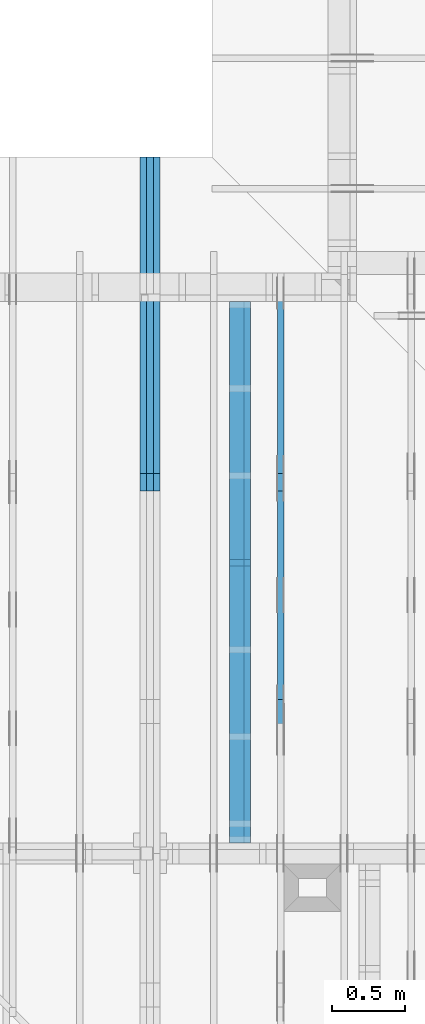
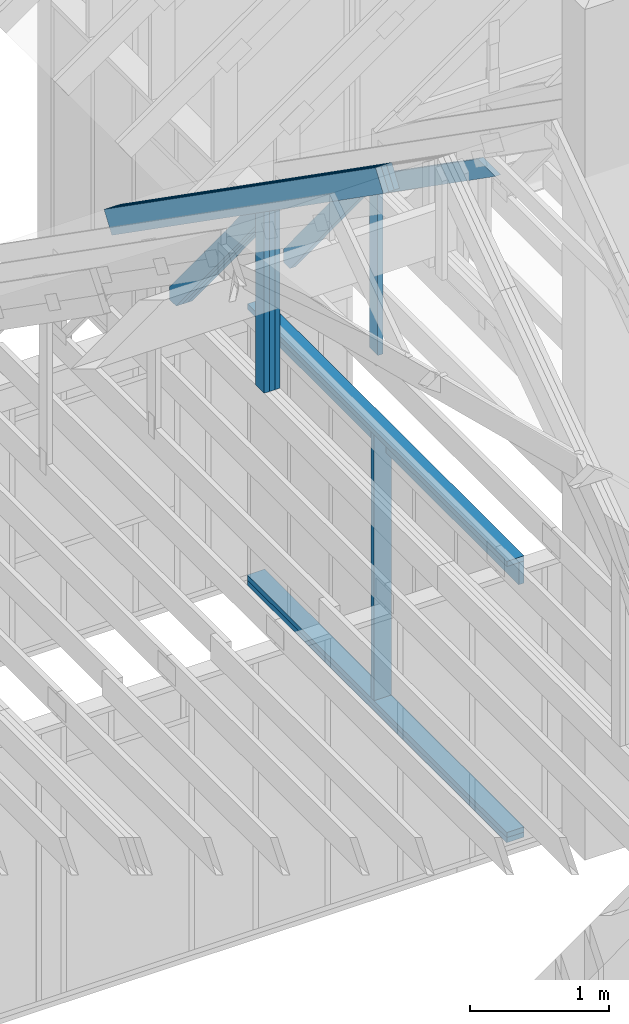
# One storey, part 18 of 70: 17 members, 3 elements without a shape of their own.
"""IFC2X3 building model written with IfcOpenShell, lengths in millimetres."""

from ifc_helpers import new_model, si_unit, frame, origin, origin_with_axes, origin_2d, place, context, project, spatial, faceted_brep, element, aggregate, save


model = new_model("IFC2X3")

# Units and contexts
model_context = context("Model", 3, precision=1e-05, world=origin())
plan_context = context("Plan", 2, precision=1e-05, world=origin_2d())
ifc_project = project(units=[si_unit("LENGTHUNIT", "METRE", prefix="MILLI"), si_unit("AREAUNIT", "SQUARE_METRE"), si_unit("VOLUMEUNIT", "CUBIC_METRE"), si_unit("SOLIDANGLEUNIT", "STERADIAN"), si_unit("PLANEANGLEUNIT", "RADIAN"), si_unit("MASSUNIT", "GRAM"), si_unit("TIMEUNIT", "SECOND"), si_unit("THERMODYNAMICTEMPERATUREUNIT", "DEGREE_CELSIUS"), si_unit("LUMINOUSINTENSITYUNIT", "LUMEN")], contexts=[model_context, plan_context])

# Site, building, storey
site_placement = place(None, origin_with_axes())
site = spatial("IfcSite", under=ifc_project, at=site_placement, CompositionType="ELEMENT")
building_placement = place(site_placement, origin_with_axes())
building = spatial("IfcBuilding", under=site, at=building_placement, Name="Layout 1", CompositionType="ELEMENT")
storey_placement = place(building_placement, origin_with_axes())
storey = spatial("IfcBuildingStorey", under=building, at=storey_placement, Name="Storey 1", CompositionType="ELEMENT", Elevation=0.0)

# Assembly, members
assembly_1_placement = place(storey_placement, frame((5660.000000000293, 8000.0, 9.122500660690286e-13), z_axis=(-1.0, 1.836909530733566e-16, 6.123031769111886e-17), x_axis=(-1.836909530733566e-16, -1.0, 0.0)))
assembly_1 = element("IfcElementAssembly", 1, at=assembly_1_placement, inside=storey, Name="T11", AssemblyPlace="FACTORY", PredefinedType="TRUSS")
member_1_placement = place(assembly_1_placement, frame((-688.1525949112561, 280.0993207951618, -90.0), z_axis=(0.0, 0.0, 1.0), x_axis=(0.8191520442889916, 0.5735764363510464, 0.0)))
member_1 = element("IfcMember", 2, at=member_1_placement, Name="T9", context=model_context, shape_type="Brep", body=[
    faceted_brep([(4768.153825500515, 195.00000000101568, 45.0), (0.0, 195.00000000101568, 45.0), (3.9250380723387934e-10, 0.0, 45.0), (4768.153825500451, 0.0, 45.0), (0.0, 195.00000000101568, 0.0), (4768.153825500515, 195.00000000101568, 5.839111470710405e-13), (4768.153825500451, 0.0, 5.839111470710327e-13), (3.9250380723387934e-10, 0.0, 4.806626562380822e-26), (3.925038072338794e-10, 9.4039548065783e-38, -2.8698592549372254e-42), (3.925065625981755e-10, 5.545142647084054e-27, 45.0), (7.104410816346931e-14, 195.00000000050545, 45.0), (6.828874386736896e-14, 195.00000000050545, -4.181341481726627e-30), (4768.153825500451, 3.103358117890669e-09, 7.360169588463904e-29), (4768.153825500451, 3.103360873254965e-09, 45.0), (3.9250380723387934e-10, 2.755364296001399e-15, 45.0), (3.9250380723387934e-10, -9.894980083356221e-26, 6.058727740512586e-42), (4768.153825500451, 195.00000000101568, -3.937993638863291e-27), (4768.153825500451, 195.00000000101568, 45.0), (4768.153825500451, 3.1045601645018905e-09, 45.0), (4768.153825500451, 3.1045601645018905e-09, 0.0), (0.0, 195.00000000050545, 0.0), (0.0, 195.00000000050545, 45.0), (4768.153825500515, 195.00000000101548, 45.0), (4768.153825500515, 195.00000000101548, -1.262177448353619e-29)], [[[0, 1, 2, 3]], [[4, 5, 6, 7]], [[8, 9, 10, 11]], [[12, 13, 14, 15]], [[16, 17, 18, 19]], [[20, 21, 22, 23]]]),
])
member_2_placement = place(assembly_1_placement, frame((-688.1525949112561, 280.0993207951618, -135.0), z_axis=(0.0, 0.0, 1.0), x_axis=(0.8191520442889916, 0.5735764363510464, 0.0)))
member_2 = element("IfcMember", 3, at=member_2_placement, Name="T9", context=model_context, shape_type="Brep", body=[
    faceted_brep([(4768.153825500515, 195.00000000101568, 45.0), (0.0, 195.00000000101568, 45.0), (3.9250380723387934e-10, 0.0, 45.0), (4768.153825500451, 0.0, 45.0), (0.0, 195.00000000101568, 0.0), (4768.153825500515, 195.00000000101568, 5.839111470710405e-13), (4768.153825500451, 0.0, 5.839111470710327e-13), (3.9250380723387934e-10, 0.0, 4.806626562380822e-26), (3.925038072338794e-10, 9.4039548065783e-38, -2.8698592549372254e-42), (3.925065625981755e-10, 5.545142647084054e-27, 45.0), (7.104410816346931e-14, 195.00000000050545, 45.0), (6.828874386736896e-14, 195.00000000050545, -4.181341481726627e-30), (4768.153825500451, 3.103358117890669e-09, 7.360169588463904e-29), (4768.153825500451, 3.103360873254965e-09, 45.0), (3.9250380723387934e-10, 2.755364296001399e-15, 45.0), (3.9250380723387934e-10, -9.894980083356221e-26, 6.058727740512586e-42), (4768.153825500451, 195.00000000101568, -3.937993638863291e-27), (4768.153825500451, 195.00000000101568, 45.0), (4768.153825500451, 3.1045601645018905e-09, 45.0), (4768.153825500451, 3.1045601645018905e-09, 0.0), (0.0, 195.00000000050545, 0.0), (0.0, 195.00000000050545, 45.0), (4768.153825500515, 195.00000000101548, 45.0), (4768.153825500515, 195.00000000101548, -1.262177448353619e-29)], [[[0, 1, 2, 3]], [[4, 5, 6, 7]], [[8, 9, 10, 11]], [[12, 13, 14, 15]], [[16, 17, 18, 19]], [[20, 21, 22, 23]]]),
])
member_3_placement = place(assembly_1_placement, frame((-688.1525949112561, 280.0993207951618, -180.0), z_axis=(0.0, 0.0, 1.0), x_axis=(0.8191520442889916, 0.5735764363510464, 0.0)))
member_3 = element("IfcMember", 4, at=member_3_placement, Name="T9", context=model_context, shape_type="Brep", body=[
    faceted_brep([(4768.153825500515, 195.00000000101568, 45.0), (0.0, 195.00000000101568, 45.0), (3.9250380723387934e-10, 0.0, 45.0), (4768.153825500451, 0.0, 45.0), (0.0, 195.00000000101568, 0.0), (4768.153825500515, 195.00000000101568, 5.839111470710405e-13), (4768.153825500451, 0.0, 5.839111470710327e-13), (3.9250380723387934e-10, 0.0, 4.806626562380822e-26), (3.925038072338794e-10, 9.4039548065783e-38, -2.8698592549372254e-42), (3.925065625981755e-10, 5.545142647084054e-27, 45.0), (7.104410816346931e-14, 195.00000000050545, 45.0), (6.828874386736896e-14, 195.00000000050545, -4.181341481726627e-30), (4768.153825500451, 3.103358117890669e-09, 7.360169588463904e-29), (4768.153825500451, 3.103360873254965e-09, 45.0), (3.9250380723387934e-10, 2.755364296001399e-15, 45.0), (3.9250380723387934e-10, -9.894980083356221e-26, 6.058727740512586e-42), (4768.153825500451, 195.00000000101568, -3.937993638863291e-27), (4768.153825500451, 195.00000000101568, 45.0), (4768.153825500451, 3.1045601645018905e-09, 45.0), (4768.153825500451, 3.1045601645018905e-09, 0.0), (0.0, 195.00000000050545, 0.0), (0.0, 195.00000000050545, 45.0), (4768.153825500515, 195.00000000101548, 45.0), (4768.153825500515, 195.00000000101548, -1.262177448353619e-29)], [[[0, 1, 2, 3]], [[4, 5, 6, 7]], [[8, 9, 10, 11]], [[12, 13, 14, 15]], [[16, 17, 18, 19]], [[20, 21, 22, 23]]]),
])
member_4_placement = place(assembly_1_placement, frame((1380.0000000018192, 1812.2602625085638, -90.0), z_axis=(0.0, 0.0, 1.0), x_axis=(-1.836909530733566e-16, -1.0, 0.0)))
member_4 = element("IfcMember", 5, at=member_4_placement, Name="R1", context=model_context, shape_type="Brep", body=[
    faceted_brep([(1592.2602625085638, 120.00000000001455, 45.0), (0.0, 120.00000000001455, 45.0), (84.02490458526881, 1.432454155292362e-11, 45.0), (1592.2602625085638, 1.432454155292362e-11, 45.0), (0.0, 120.00000000001455, 0.0), (1592.2602625085638, 120.00000000001455, 1.9498920344068735e-13), (1592.2602625085638, 1.432454155292362e-11, 1.9498920344068735e-13), (84.02490458526881, 1.432454155292362e-11, 1.0289743203443919e-14), (84.0249045852688, 1.4303225270850817e-11, 1.5777218104420236e-30), (84.02490458526881, 1.4303225270850817e-11, 45.0), (2.1316282072803006e-14, 120.00000000001435, 45.0), (2.1316282072803006e-14, 120.00000000001435, -2.3665827156630354e-30), (1592.2602625085638, -7.262347142616226e-13, 4.446758227255812e-29), (1592.2602625085638, -7.234793499655223e-13, 45.0), (84.02490458526881, 1.4288972904488156e-11, 45.0), (84.02490458526881, 1.4286217540192056e-11, 2.3465914747521543e-30), (1592.2602625085638, 120.00000000001455, 0.0), (1592.2602625085638, 120.00000000001455, 45.0), (1592.2602625085638, 0.0, 45.0), (1592.2602625085638, 0.0, 0.0), (0.0, 120.00000000001432, 0.0), (0.0, 120.00000000001432, 45.0), (1592.2602625085638, 120.00000000001458, 45.0), (1592.2602625085638, 120.00000000001458, 1.5777218104420236e-30)], [[[0, 1, 2, 3]], [[4, 5, 6, 7]], [[8, 9, 10, 11]], [[12, 13, 14, 15]], [[16, 17, 18, 19]], [[20, 21, 22, 23]]]),
])
member_5_placement = place(assembly_1_placement, frame((1380.0000000018192, 1812.2602625085638, -135.0), z_axis=(0.0, 0.0, 1.0), x_axis=(-1.836909530733566e-16, -1.0, 0.0)))
member_5 = element("IfcMember", 6, at=member_5_placement, Name="R1", context=model_context, shape_type="Brep", body=[
    faceted_brep([(1592.2602625085638, 120.00000000001455, 45.0), (0.0, 120.00000000001455, 45.0), (84.02490458526881, 1.432454155292362e-11, 45.0), (1592.2602625085638, 1.432454155292362e-11, 45.0), (0.0, 120.00000000001455, 0.0), (1592.2602625085638, 120.00000000001455, 1.9498920344068735e-13), (1592.2602625085638, 1.432454155292362e-11, 1.9498920344068735e-13), (84.02490458526881, 1.432454155292362e-11, 1.0289743203443919e-14), (84.0249045852688, 1.4303225270850817e-11, 1.5777218104420236e-30), (84.02490458526881, 1.4303225270850817e-11, 45.0), (2.1316282072803006e-14, 120.00000000001435, 45.0), (2.1316282072803006e-14, 120.00000000001435, -2.3665827156630354e-30), (1592.2602625085638, -7.262347142616226e-13, 4.446758227255812e-29), (1592.2602625085638, -7.234793499655223e-13, 45.0), (84.02490458526881, 1.4288972904488156e-11, 45.0), (84.02490458526881, 1.4286217540192056e-11, 2.3465914747521543e-30), (1592.2602625085638, 120.00000000001455, 0.0), (1592.2602625085638, 120.00000000001455, 45.0), (1592.2602625085638, 0.0, 45.0), (1592.2602625085638, 0.0, 0.0), (0.0, 120.00000000001432, 0.0), (0.0, 120.00000000001432, 45.0), (1592.2602625085638, 120.00000000001458, 45.0), (1592.2602625085638, 120.00000000001458, 1.5777218104420236e-30)], [[[0, 1, 2, 3]], [[4, 5, 6, 7]], [[8, 9, 10, 11]], [[12, 13, 14, 15]], [[16, 17, 18, 19]], [[20, 21, 22, 23]]]),
])
member_6_placement = place(assembly_1_placement, frame((1380.0000000018192, 1812.2602625085638, -180.0), z_axis=(0.0, 0.0, 1.0), x_axis=(-1.836909530733566e-16, -1.0, 0.0)))
member_6 = element("IfcMember", 7, at=member_6_placement, Name="R1", context=model_context, shape_type="Brep", body=[
    faceted_brep([(1592.2602625085638, 120.00000000001455, 45.0), (0.0, 120.00000000001455, 45.0), (84.02490458526881, 1.432454155292362e-11, 45.0), (1592.2602625085638, 1.432454155292362e-11, 45.0), (0.0, 120.00000000001455, 0.0), (1592.2602625085638, 120.00000000001455, 1.9498920344068735e-13), (1592.2602625085638, 1.432454155292362e-11, 1.9498920344068735e-13), (84.02490458526881, 1.432454155292362e-11, 1.0289743203443919e-14), (84.0249045852688, 1.4303225270850817e-11, 1.5777218104420236e-30), (84.02490458526881, 1.4303225270850817e-11, 45.0), (2.1316282072803006e-14, 120.00000000001435, 45.0), (2.1316282072803006e-14, 120.00000000001435, -2.3665827156630354e-30), (1592.2602625085638, -7.262347142616226e-13, 4.446758227255812e-29), (1592.2602625085638, -7.234793499655223e-13, 45.0), (84.02490458526881, 1.4288972904488156e-11, 45.0), (84.02490458526881, 1.4286217540192056e-11, 2.3465914747521543e-30), (1592.2602625085638, 120.00000000001455, 0.0), (1592.2602625085638, 120.00000000001455, 45.0), (1592.2602625085638, 0.0, 45.0), (1592.2602625085638, 0.0, 0.0), (0.0, 120.00000000001432, 0.0), (0.0, 120.00000000001432, 45.0), (1592.2602625085638, 120.00000000001458, 45.0), (1592.2602625085638, 120.00000000001458, 1.5777218104420236e-30)], [[[0, 1, 2, 3]], [[4, 5, 6, 7]], [[8, 9, 10, 11]], [[12, 13, 14, 15]], [[16, 17, 18, 19]], [[20, 21, 22, 23]]]),
])
member_7_placement = place(assembly_1_placement, frame((1323.9061318637646, 1774.1671329520943, -90.0), z_axis=(0.0, 0.0, 1.0), x_axis=(-0.6335417245359891, -0.7737085260432154, 0.0)))
member_7 = element("IfcMember", 8, at=member_7_placement, Name="W6", context=model_context, shape_type="Brep", body=[
    faceted_brep([(1889.9928508900764, 145.0000000000005, 45.0), (88.54013234768809, 145.0000000000005, 45.0), (0.0, 72.49999999991722, 45.0), (258.1329393161973, 8.952838470577262e-13, 45.0), (1860.8184531629986, 8.952838470577262e-13, 45.0), (1949.3585855093759, 72.49999999991722, 45.0), (88.54013234768809, 145.0000000000005, 1.0842680864125302e-14), (1889.9928508900764, 145.0000000000005, 2.3144972538788564e-13), (1949.3585855093759, 72.49999999991722, 2.3871969096929837e-13), (1860.8184531629986, 8.952838470577262e-13, 2.2787701010533356e-13), (258.1329393161973, 8.952838470577262e-13, 3.161112376174613e-14), (0.0, 72.49999999991722, 0.0), (-7.105427357601002e-15, 72.49999999991722, 3.944304526105059e-31), (-7.105427357601002e-15, 72.49999999991722, 45.0), (88.54013234768809, 145.00000000000068, 45.0), (88.54013234768809, 145.00000000000068, 0.0), (258.1329393161972, 8.668621376273222e-13, 2.389641596425483e-30), (258.1329393161972, 8.668621376273222e-13, 45.0), (-3.552713678800501e-15, 72.4999999999172, 45.0), (-3.552713678800501e-15, 72.49999999991718, 1.6381313700805284e-30), (1860.8184531629986, -9.550735810262884e-13, 5.847945878463418e-29), (1860.8184531629986, -9.52318216730188e-13, 45.0), (258.1329393161973, 7.655512997499284e-13, 45.0), (258.1329393161973, 7.62795935453828e-13, 8.112276917739558e-30), (1949.358585509376, 72.4999999985614, 1.2621774483536192e-29), (1949.358585509376, 72.4999999985614, 45.0), (1860.818453162999, -2.2737367544323206e-13, 45.0), (1860.818453162999, -2.2737367544323206e-13, 1.2621774483536192e-29), (1889.9928508900764, 145.00000000000034, 0.0), (1889.9928508900764, 145.00000000000034, 45.0), (1949.3585855093759, 72.4999999985613, 45.0), (1949.3585855093759, 72.4999999985613, -1.262177448353619e-29), (88.54013234768809, 145.00000000000068, 0.0), (88.54013234768809, 145.00000000000068, 45.0), (1889.9928508900764, 145.00000000000057, 45.0), (1889.9928508900764, 145.00000000000057, 3.1554436208840472e-30)], [[[0, 1, 2, 3, 4, 5]], [[6, 7, 8, 9, 10, 11]], [[12, 13, 14, 15]], [[16, 17, 18, 19]], [[20, 21, 22, 23]], [[24, 25, 26, 27]], [[28, 29, 30, 31]], [[32, 33, 34, 35]]]),
])
member_8_placement = place(assembly_1_placement, frame((1323.9061318637646, 1774.1671329520943, -135.0), z_axis=(0.0, 0.0, 1.0), x_axis=(-0.6335417245359891, -0.7737085260432154, 0.0)))
member_8 = element("IfcMember", 9, at=member_8_placement, Name="W6", context=model_context, shape_type="Brep", body=[
    faceted_brep([(1889.9928508900764, 145.0000000000005, 45.0), (88.54013234768809, 145.0000000000005, 45.0), (0.0, 72.49999999991722, 45.0), (258.1329393161973, 8.952838470577262e-13, 45.0), (1860.8184531629986, 8.952838470577262e-13, 45.0), (1949.3585855093759, 72.49999999991722, 45.0), (88.54013234768809, 145.0000000000005, 1.0842680864125302e-14), (1889.9928508900764, 145.0000000000005, 2.3144972538788564e-13), (1949.3585855093759, 72.49999999991722, 2.3871969096929837e-13), (1860.8184531629986, 8.952838470577262e-13, 2.2787701010533356e-13), (258.1329393161973, 8.952838470577262e-13, 3.161112376174613e-14), (0.0, 72.49999999991722, 0.0), (-7.105427357601002e-15, 72.49999999991722, 3.944304526105059e-31), (-7.105427357601002e-15, 72.49999999991722, 45.0), (88.54013234768809, 145.00000000000068, 45.0), (88.54013234768809, 145.00000000000068, 0.0), (258.1329393161972, 8.668621376273222e-13, 2.389641596425483e-30), (258.1329393161972, 8.668621376273222e-13, 45.0), (-3.552713678800501e-15, 72.4999999999172, 45.0), (-3.552713678800501e-15, 72.49999999991718, 1.6381313700805284e-30), (1860.8184531629986, -9.550735810262884e-13, 5.847945878463418e-29), (1860.8184531629986, -9.52318216730188e-13, 45.0), (258.1329393161973, 7.655512997499284e-13, 45.0), (258.1329393161973, 7.62795935453828e-13, 8.112276917739558e-30), (1949.358585509376, 72.4999999985614, 1.2621774483536192e-29), (1949.358585509376, 72.4999999985614, 45.0), (1860.818453162999, -2.2737367544323206e-13, 45.0), (1860.818453162999, -2.2737367544323206e-13, 1.2621774483536192e-29), (1889.9928508900764, 145.00000000000034, 0.0), (1889.9928508900764, 145.00000000000034, 45.0), (1949.3585855093759, 72.4999999985613, 45.0), (1949.3585855093759, 72.4999999985613, -1.262177448353619e-29), (88.54013234768809, 145.00000000000068, 0.0), (88.54013234768809, 145.00000000000068, 45.0), (1889.9928508900764, 145.00000000000057, 45.0), (1889.9928508900764, 145.00000000000057, 3.1554436208840472e-30)], [[[0, 1, 2, 3, 4, 5]], [[6, 7, 8, 9, 10, 11]], [[12, 13, 14, 15]], [[16, 17, 18, 19]], [[20, 21, 22, 23]], [[24, 25, 26, 27]], [[28, 29, 30, 31]], [[32, 33, 34, 35]]]),
])
member_9_placement = place(assembly_1_placement, frame((1323.9061318637646, 1774.1671329520943, -180.0), z_axis=(0.0, 0.0, 1.0), x_axis=(-0.6335417245359891, -0.7737085260432154, 0.0)))
member_9 = element("IfcMember", 10, at=member_9_placement, Name="W6", context=model_context, shape_type="Brep", body=[
    faceted_brep([(1889.9928508900764, 145.0000000000005, 45.0), (88.54013234768809, 145.0000000000005, 45.0), (0.0, 72.49999999991722, 45.0), (258.1329393161973, 8.952838470577262e-13, 45.0), (1860.8184531629986, 8.952838470577262e-13, 45.0), (1949.3585855093759, 72.49999999991722, 45.0), (88.54013234768809, 145.0000000000005, 1.0842680864125302e-14), (1889.9928508900764, 145.0000000000005, 2.3144972538788564e-13), (1949.3585855093759, 72.49999999991722, 2.3871969096929837e-13), (1860.8184531629986, 8.952838470577262e-13, 2.2787701010533356e-13), (258.1329393161973, 8.952838470577262e-13, 3.161112376174613e-14), (0.0, 72.49999999991722, 0.0), (-7.105427357601002e-15, 72.49999999991722, 3.944304526105059e-31), (-7.105427357601002e-15, 72.49999999991722, 45.0), (88.54013234768809, 145.00000000000068, 45.0), (88.54013234768809, 145.00000000000068, 0.0), (258.1329393161972, 8.668621376273222e-13, 2.389641596425483e-30), (258.1329393161972, 8.668621376273222e-13, 45.0), (-3.552713678800501e-15, 72.4999999999172, 45.0), (-3.552713678800501e-15, 72.49999999991718, 1.6381313700805284e-30), (1860.8184531629986, -9.550735810262884e-13, 5.847945878463418e-29), (1860.8184531629986, -9.52318216730188e-13, 45.0), (258.1329393161973, 7.655512997499284e-13, 45.0), (258.1329393161973, 7.62795935453828e-13, 8.112276917739558e-30), (1949.358585509376, 72.4999999985614, 1.2621774483536192e-29), (1949.358585509376, 72.4999999985614, 45.0), (1860.818453162999, -2.2737367544323206e-13, 45.0), (1860.818453162999, -2.2737367544323206e-13, 1.2621774483536192e-29), (1889.9928508900764, 145.00000000000034, 0.0), (1889.9928508900764, 145.00000000000034, 45.0), (1949.3585855093759, 72.4999999985613, 45.0), (1949.3585855093759, 72.4999999985613, -1.262177448353619e-29), (88.54013234768809, 145.00000000000068, 0.0), (88.54013234768809, 145.00000000000068, 45.0), (1889.9928508900764, 145.00000000000057, 45.0), (1889.9928508900764, 145.00000000000057, 3.1554436208840472e-30)], [[[0, 1, 2, 3, 4, 5]], [[6, 7, 8, 9, 10, 11]], [[12, 13, 14, 15]], [[16, 17, 18, 19]], [[20, 21, 22, 23]], [[24, 25, 26, 27]], [[28, 29, 30, 31]], [[32, 33, 34, 35]]]),
])
aggregate(assembly_1, [member_1, member_2, member_3, member_4, member_5, member_6, member_7, member_8, member_9])

assembly_2_placement = place(storey_placement, frame((6650.000000000001, 8000.0, -9.081170196248781e-13), z_axis=(-1.0, 1.836909530733566e-16, 6.123031769111886e-17), x_axis=(-1.836909530733566e-16, -1.0, 0.0)))
assembly_2 = element("IfcElementAssembly", 11, at=assembly_2_placement, inside=storey, Name="T12", AssemblyPlace="FACTORY", PredefinedType="TRUSS")
member_10_placement = place(assembly_2_placement, frame((1380.0000000018192, 1812.2602625085638, -45.0), z_axis=(0.0, 0.0, 1.0), x_axis=(-1.836909530733566e-16, -1.0, 0.0)))
member_10 = element("IfcMember", 12, at=member_10_placement, Name="R1", context=model_context, shape_type="Brep", body=[
    faceted_brep([(1592.2602625085638, 120.00000000001455, 45.0), (0.0, 120.00000000001455, 45.0), (84.02490458526881, 1.432454155292362e-11, 45.0), (1592.2602625085638, 1.432454155292362e-11, 45.0), (0.0, 120.00000000001455, 0.0), (1592.2602625085638, 120.00000000001455, 1.9498920344068735e-13), (1592.2602625085638, 1.432454155292362e-11, 1.9498920344068735e-13), (84.02490458526881, 1.432454155292362e-11, 1.0289743203443919e-14), (84.0249045852688, 1.4303225270850817e-11, 1.5777218104420236e-30), (84.02490458526881, 1.4303225270850817e-11, 45.0), (2.1316282072803006e-14, 120.00000000001435, 45.0), (2.1316282072803006e-14, 120.00000000001435, -2.3665827156630354e-30), (1592.2602625085638, -7.262347142616226e-13, 4.446758227255812e-29), (1592.2602625085638, -7.234793499655223e-13, 45.0), (84.02490458526881, 1.4288972904488156e-11, 45.0), (84.02490458526881, 1.4286217540192056e-11, 2.3465914747521543e-30), (1592.2602625085638, 120.00000000001455, 0.0), (1592.2602625085638, 120.00000000001455, 45.0), (1592.2602625085638, 0.0, 45.0), (1592.2602625085638, 0.0, 0.0), (0.0, 120.00000000001432, 0.0), (0.0, 120.00000000001432, 45.0), (1592.2602625085638, 120.00000000001458, 45.0), (1592.2602625085638, 120.00000000001458, 1.5777218104420236e-30)], [[[0, 1, 2, 3]], [[4, 5, 6, 7]], [[8, 9, 10, 11]], [[12, 13, 14, 15]], [[16, 17, 18, 19]], [[20, 21, 22, 23]]]),
])
member_11_placement = place(assembly_2_placement, frame((1323.9061318638364, 1774.1671329521819, -45.0), z_axis=(0.0, 0.0, 1.0), x_axis=(-0.6335417245359891, -0.7737085260432154, 0.0)))
member_11 = element("IfcMember", 13, at=member_11_placement, Name="W6", context=model_context, shape_type="Brep", body=[
    faceted_brep([(1889.9928508901896, 145.00000000000045, 45.0), (88.54013234780132, 145.00000000000045, 45.0), (0.0, 72.4999999998246, 45.0), (258.1329393158155, 1.0373923942097463e-12, 45.0), (1860.818453163112, 1.0373923942097463e-12, 45.0), (1949.358585509489, 72.4999999998246, 45.0), (88.54013234780132, 145.00000000000045, 1.0842680864139169e-14), (1889.9928508901896, 145.00000000000045, 2.314497253878995e-13), (1949.358585509489, 72.4999999998246, 2.387196909693122e-13), (1860.818453163112, 1.0373923942097463e-12, 2.278770101053475e-13), (258.1329393158155, 1.0373923942097463e-12, 3.161112376169938e-14), (0.0, 72.4999999998246, 0.0), (1.4210854715202004e-14, 72.49999999982458, -1.1832913578315177e-30), (1.4210854715202004e-14, 72.49999999982458, 45.0), (88.54013234780135, 145.00000000000057, 45.0), (88.54013234780135, 145.00000000000057, -7.888609052210118e-31), (258.13293931581546, 9.094947017729282e-13, 9.44327198188855e-30), (258.13293931581546, 9.094947017729282e-13, 45.0), (0.0, 72.49999999982461, 45.0), (0.0, 72.49999999982461, -8.492704648594505e-31), (1860.818453163112, -7.900766401995888e-13, 4.837664367975264e-29), (1860.818453163112, -7.873212759034885e-13, 45.0), (258.1329393158155, 9.305482405771586e-13, 45.0), (258.1329393158155, 9.277928762810583e-13, 6.710813301567046e-30), (1949.3585855094898, 72.4999999985605, 7.573064690121713e-29), (1949.3585855094898, 72.4999999985605, 45.0), (1860.8184531631127, -7.958078640513122e-13, 45.0), (1860.8184531631127, -7.958078640513122e-13, 6.310887241768094e-29), (1889.9928508901896, 145.00000000000057, 1.262177448353619e-29), (1889.9928508901896, 145.00000000000057, 45.0), (1949.358585509489, 72.49999999856152, 45.0), (1949.358585509489, 72.49999999856152, 1.262177448353619e-29), (88.54013234780132, 145.00000000000057, 0.0), (88.54013234780132, 145.00000000000057, 45.0), (1889.9928508901896, 145.00000000000045, 45.0), (1889.9928508901896, 145.00000000000045, 0.0)], [[[0, 1, 2, 3, 4, 5]], [[6, 7, 8, 9, 10, 11]], [[12, 13, 14, 15]], [[16, 17, 18, 19]], [[20, 21, 22, 23]], [[24, 25, 26, 27]], [[28, 29, 30, 31]], [[32, 33, 34, 35]]]),
])
member_12_placement = place(assembly_2_placement, frame((1500.0000000037453, 1635.2479181258152, -45.0), z_axis=(0.0, 0.0, 1.0), x_axis=(0.8191520442888451, 0.5735764363512555, 0.0)))
member_12 = element("IfcMember", 14, at=member_12_placement, Name="SC5", context=model_context, shape_type="Brep", body=[
    faceted_brep([(1858.4707597647894, 145.00000000266346, 45.0), (101.53009304256966, 145.00000000266346, 45.0), (0.0, 3.688342076202389e-09, 45.0), (2065.55222074634, 3.688342076202389e-09, 45.0), (101.53009304256966, 145.00000000266346, 1.2433439704410794e-14), (1858.4707597647894, 145.00000000266346, 2.275895100801062e-13), (2065.55222074634, 3.688342076202389e-09, 2.5294883736778897e-13), (0.0, 3.688342076202389e-09, 0.0), (1.5396149491358557e-14, 3.6883312957024557e-09, -1.1508377854362918e-30), (1.7653211787265022e-14, 3.6883297152904218e-09, 45.0), (101.5300930425697, 145.00000000634097, 45.0), (101.5300930425697, 145.00000000634097, -4.4400388937903335e-30), (2065.55222074634, -1.3755294943362107e-12, 8.422410793172656e-29), (2065.55222074634, -1.3727741300401104e-12, 45.0), (4.921936153727107e-27, 3.688344831566685e-09, 45.0), (0.0, 3.688342076202389e-09, 0.0), (1858.4707597647896, 145.00000000266334, -1.262177448353619e-29), (1858.4707597647896, 145.00000000266334, 45.0), (2065.55222074634, -1.1368683772161603e-13, 45.0), (2065.55222074634, -1.1368683772161603e-13, -1.262177448353619e-29), (101.53009304256966, 145.000000006341, 0.0), (101.53009304256966, 145.000000006341, 45.0), (1858.4707597647894, 145.00000000266363, 45.0), (1858.4707597647894, 145.00000000266363, 9.466330862652142e-30)], [[[0, 1, 2, 3]], [[4, 5, 6, 7]], [[8, 9, 10, 11]], [[12, 13, 14, 15]], [[16, 17, 18, 19]], [[20, 21, 22, 23]]]),
])
aggregate(assembly_2, [member_10, member_11, member_12])

assembly_3_placement = place(storey_placement, frame((6320.15185546875, 7805.0, -2470.0), z_axis=(-1.0, 1.836909530733566e-16, 6.123031769111886e-17), x_axis=(-1.836909530733566e-16, -1.0, 0.0)))
assembly_3 = element("IfcElementAssembly", 15, at=assembly_3_placement, inside=storey, Name="VE7", AssemblyPlace="FACTORY", PredefinedType="NOTDEFINED")
member_13_placement = place(assembly_3_placement, frame((1.457281561048629e-13, 2425.0, -145.0), z_axis=(0.0, 0.0, 1.0), x_axis=(1.0, 0.0, 0.0)))
member_13 = element("IfcMember", 16, at=member_13_placement, Name="P15", context=model_context, shape_type="Brep", body=[
    faceted_brep([(3732.4999999999986, 45.0, 145.0), (2.755364296100349e-15, 45.0, 145.0), (0.0, 0.0, 145.0), (3732.4999999999986, 0.0, 145.0), (2.755364296100349e-15, 45.0, 3.3742366240998092e-31), (3732.4999999999986, 45.0, 4.570843215642021e-13), (3732.4999999999986, 0.0, 4.570843215642021e-13), (0.0, 0.0, 0.0), (-3.944304526105059e-31, 4.830220384078616e-47, 2.415110192039308e-47), (8.878396065212235e-15, -1.0872540233210496e-30, 145.0), (1.4389124657412933e-14, 45.0, 145.0), (5.510728592200698e-15, 45.0, -1.6871183120499044e-31), (3732.4999999999986, -6.856264823463033e-13, 4.1981127331508443e-29), (3732.4999999999986, -6.76748086281091e-13, 145.0), (1.6308810349815745e-30, 8.878396065212235e-15, 145.0), (0.0, 0.0, 0.0), (3732.4999999999986, 45.0, 0.0), (3732.4999999999986, 45.0, 145.0), (3732.4999999999986, 0.0, 145.0), (3732.4999999999986, 0.0, 0.0), (2.755364296100349e-15, 45.0, 0.0), (2.7553642961003484e-15, 44.99999999999999, 145.0), (3732.4999999999986, 44.999999999999766, 145.0), (3732.4999999999986, 44.99999999999977, -1.3805065841367707e-29)], [[[0, 1, 2, 3]], [[4, 5, 6, 7]], [[8, 9, 10, 11]], [[12, 13, 14, 15]], [[16, 17, 18, 19]], [[20, 21, 22, 23]]]),
])
member_14_placement = place(assembly_3_placement, frame((3732.499999999998, 90.0, -145.0), z_axis=(0.0, 0.0, 1.0), x_axis=(-1.0, 1.2246063538223773e-16, 0.0)))
member_14 = element("IfcMember", 17, at=member_14_placement, Name="P15", context=model_context, shape_type="Brep", body=[
    faceted_brep([(3732.499999999998, 45.000000000000455, 145.0), (0.0, 45.000000000000455, 145.0), (0.0, 0.0, 145.0), (3732.499999999998, 0.0, 145.0), (0.0, 45.000000000000455, 0.0), (3732.499999999998, 45.000000000000455, 4.570843215642021e-13), (3732.499999999998, 0.0, 4.570843215642021e-13), (0.0, 0.0, 0.0), (0.0, 0.0, 0.0), (8.878396065212235e-15, -1.0872540233210496e-30, 145.0), (1.4389124657412933e-14, 45.0, 145.0), (5.510728592200698e-15, 45.0, -3.3742366240998092e-31), (3732.499999999998, -6.856264823463032e-13, 6.982545209548134e-29), (3732.499999999998, -6.767480862810909e-13, 145.0), (1.6308810349815745e-30, 8.878396065212235e-15, 145.0), (0.0, 0.0, 0.0), (3732.499999999998, 45.000000000000455, 0.0), (3732.499999999998, 45.000000000000455, 145.0), (3732.499999999998, 4.547473508864641e-13, 145.0), (3732.499999999998, 4.547473508864641e-13, 0.0), (0.0, 45.0, 0.0), (1.5777218104420236e-30, 44.99999999999999, 145.0), (3732.499999999998, 45.00000000000059, 145.0), (3732.499999999998, 45.0000000000006, 8.67746995743113e-30)], [[[0, 1, 2, 3]], [[4, 5, 6, 7]], [[8, 9, 10, 11]], [[12, 13, 14, 15]], [[16, 17, 18, 19]], [[20, 21, 22, 23]]]),
])
member_15_placement = place(assembly_3_placement, frame((1.3378824415499132e-13, 2229.9999999981374, -145.0), z_axis=(0.0, 0.0, 1.0), x_axis=(1.0, 0.0, 0.0)))
member_15 = element("IfcMember", 18, at=member_15_placement, Name="L5", context=model_context, shape_type="Brep", body=[
    faceted_brep([(3732.4999999999986, 195.00000000186265, 45.0), (1.1939911949871576e-14, 195.00000000186265, 45.0), (0.0, 0.0, 45.0), (3732.4999999999986, 0.0, 45.0), (1.1939911949871576e-14, 195.00000000186265, 1.4621692037892461e-30), (3732.4999999999986, 195.00000000186265, 4.570843215642021e-13), (3732.4999999999986, 0.0, 4.570843215642021e-13), (0.0, 0.0, 0.0), (0.0, 0.0, 0.0), (2.755364296100349e-15, -3.3742366240998092e-31, 45.0), (2.6635188195864806e-14, 195.00000000186265, 45.0), (2.3879823899764457e-14, 195.00000000186265, -7.310846018959277e-31), (3732.4999999999986, 1.8624151582779163e-09, 1.4082419120776842e-29), (3732.4999999999986, 1.8624179136422124e-09, 45.0), (-1.3748512341955934e-27, 2.755364296100349e-15, 45.0), (0.0, 0.0, 0.0), (3732.4999999999986, 195.00000000186265, 0.0), (3732.4999999999986, 195.00000000186265, 45.0), (3732.4999999999986, 1.862645149230957e-09, 45.0), (3732.4999999999986, 1.862645149230957e-09, 0.0), (1.1939911949871576e-14, 195.00000000186265, 0.0), (1.1939911949871576e-14, 195.00000000186265, 45.0), (3732.4999999999986, 195.00000000186242, 45.0), (3732.4999999999986, 195.00000000186242, -1.4199496293978212e-29)], [[[0, 1, 2, 3]], [[4, 5, 6, 7]], [[8, 9, 10, 11]], [[12, 13, 14, 15]], [[16, 17, 18, 19]], [[20, 21, 22, 23]]]),
])
member_16_placement = place(assembly_3_placement, frame((3732.499999999998, 45.0, -145.0), z_axis=(0.0, 0.0, 1.0), x_axis=(-1.0, 1.2246063538223773e-16, 0.0)))
member_16 = element("IfcMember", 19, at=member_16_placement, Name="P15", context=model_context, shape_type="Brep", body=[
    faceted_brep([(3732.499999999998, 45.000000000000455, 145.0), (0.0, 45.000000000000455, 145.0), (0.0, 0.0, 145.0), (3732.499999999998, 0.0, 145.0), (0.0, 45.000000000000455, 0.0), (3732.499999999998, 45.000000000000455, 4.570843215642021e-13), (3732.499999999998, 0.0, 4.570843215642021e-13), (0.0, 0.0, 0.0), (0.0, 0.0, 0.0), (8.878396065212235e-15, -1.0872540233210496e-30, 145.0), (1.4389124657641033e-14, 45.000000001862645, 145.0), (5.510728592428798e-15, 45.000000001862645, -3.3742366242394762e-31), (3732.499999999998, -6.856264823463032e-13, 6.982545209548134e-29), (3732.499999999998, -6.767480862810909e-13, 145.0), (1.6308810349815745e-30, 8.878396065212235e-15, 145.0), (0.0, 0.0, 0.0), (3732.499999999998, 45.000000000000455, 0.0), (3732.499999999998, 45.000000000000455, 145.0), (3732.499999999998, 4.547473508864641e-13, 145.0), (3732.499999999998, 4.547473508864641e-13, 0.0), (0.0, 45.000000001862645, 0.0), (-3.2311742677852644e-27, 45.00000000186264, 145.0), (3732.499999999998, 45.000000000000135, 145.0), (3732.499999999998, 45.00000000000014, -1.932709217791479e-29)], [[[0, 1, 2, 3]], [[4, 5, 6, 7]], [[8, 9, 10, 11]], [[12, 13, 14, 15]], [[16, 17, 18, 19]], [[20, 21, 22, 23]]]),
])
member_17_placement = place(assembly_3_placement, frame((1777.5000000018335, 2425.0, -145.0), z_axis=(0.0, 0.0, 1.0), x_axis=(-1.836909530733566e-16, -1.0, 0.0)))
member_17 = element("IfcMember", 20, at=member_17_placement, Name="S42", context=model_context, shape_type="Brep", body=[
    faceted_brep([(0.0, 44.99999999998545, 45.0), (195.00000000186265, 44.99999999998545, 45.00000000000002), (195.00000000186265, 0.0, 45.00000000000002), (0.0, 0.0, 45.0), (195.00000000186265, 0.0, 0.0), (195.00000000186265, -3.3742366240998092e-31, 45.0), (195.00000000186265, 44.999999999986585, 45.0), (195.00000000186265, 44.999999999986585, 0.0), (2.755364296100349e-15, -3.3742366240998092e-31, 45.0), (8.878396065212235e-15, -1.0872540233210496e-30, 145.0), (1.438912465741115e-14, 44.99999999998545, 145.0), (8.266092888299264e-15, 44.99999999998545, 45.0), (2335.0, -4.2891837542628763e-13, 2.626280839091018e-29), (2335.0, -4.200399793610754e-13, 145.0), (1.6308810349815745e-30, 8.878396065212235e-15, 145.0), (5.061354936149714e-31, 2.755364296100349e-15, 45.0), (195.00000000186265, -3.306437155354634e-14, 45.0), (195.00000000186265, -3.5819735849646686e-14, 2.193253805685826e-30), (-1.6871183120499046e-31, 44.999999999986585, 45.0), (-5.436270116605248e-31, 44.99999999998658, 145.0), (2335.0, 44.999999999986436, 145.0), (2335.0, 44.99999999998644, -8.67746995743113e-30), (195.00000000186265, 44.99999999998657, -7.888609052210118e-31), (195.00000000186265, 44.99999999998657, 45.0), (2335.0, 45.000000000000455, 2.842170943040401e-14), (2335.0, 45.000000000000455, 145.0), (2335.0, 4.547473508864641e-13, 145.0), (2335.0, 4.547473508864641e-13, 0.0), (2335.0, 45.000000000000455, 145.0), (0.0, 45.000000000000455, 145.0), (0.0, 0.0, 145.0), (2335.0, 0.0, 145.0), (195.00000000186265, 44.999999999986585, 2.3879823899764457e-14), (2335.0, 44.999999999986585, 2.859455836175251e-13), (2335.0, 4.547473508864641e-13, 2.859455836175251e-13), (195.00000000186265, 4.547473508864641e-13, 2.3879823899764457e-14)], [[[0, 1, 2, 3]], [[4, 5, 6, 7]], [[8, 9, 10, 11]], [[12, 13, 14, 15, 16, 17]], [[18, 19, 20, 21, 22, 23]], [[24, 25, 26, 27]], [[28, 29, 30, 31]], [[32, 33, 34, 35]]]),
])
aggregate(assembly_3, [member_13, member_14, member_15, member_16, member_17])

save(model, "model.ifc")
